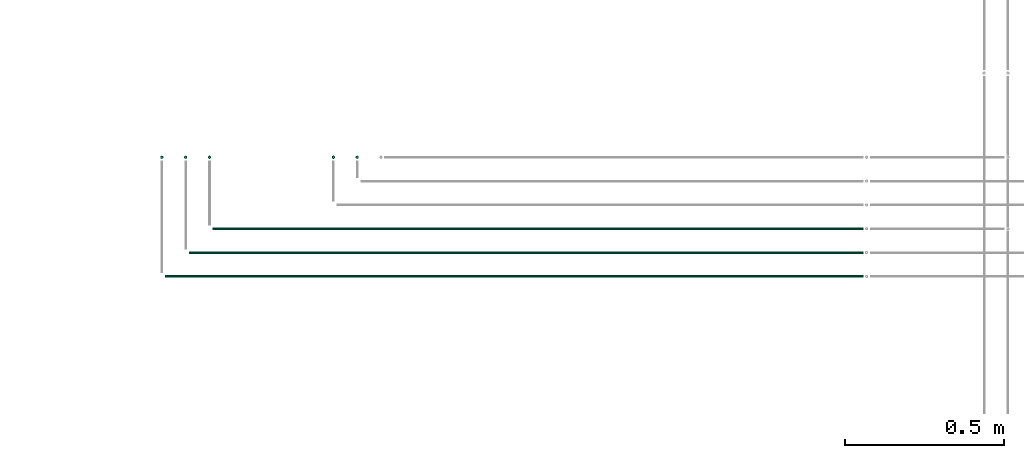
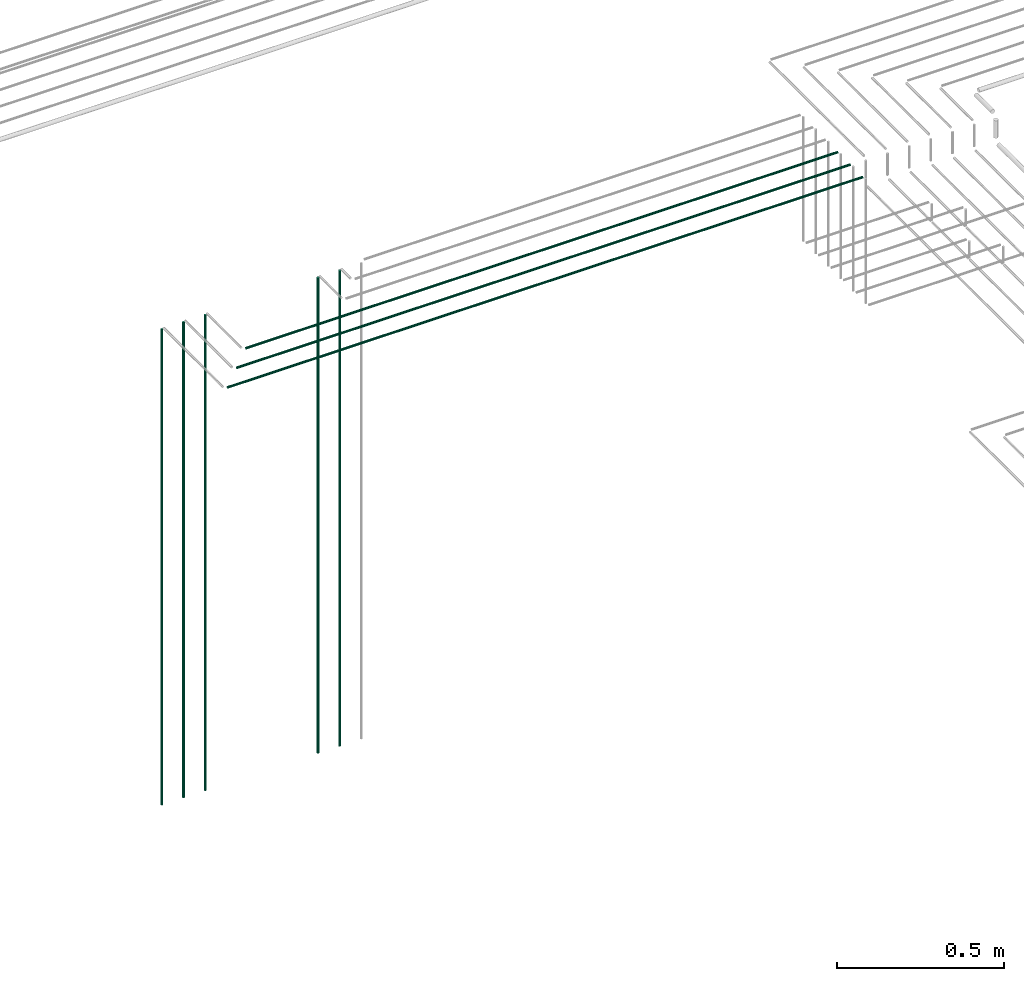
# One storey, part 21 of 89: 8 flow segments.
"""IFC2X3 building model written with IfcOpenShell, lengths in millimetres."""

import ifcopenshell
import ifcopenshell.guid

model = None  # the IFC model being written
_history = None  # IfcOwnerHistory: only IFC2X3 demands one
_inside = {}  # id of a spatial element -> (the spatial element, [elements in it])
_under = {}  # id of a project, library or spatial element -> (it, [spatial elements below it])
_declared = {}  # id of a project -> (the project, [libraries it declares])
_typed = {}  # id of a type object -> (the type object, [elements of that type])
_made_of = {}  # id of a material, layer set ... -> (it, [elements and type objects made of it])


def new_model(schema):
    """Start an empty IFC model of exactly this schema.

    Asked for "IFC4X3", IfcOpenShell would pick the latest addendum, in which some entities
    have other attributes; the version numbers below select the first issue.
    IFC2X3 requires an IfcOwnerHistory on every rooted entity: one is made here for all.
    """
    global model, _history
    if schema == "IFC4X3":
        model = ifcopenshell.file(schema_version=(4, 3, 0, 0))
    else:
        model = ifcopenshell.file(schema=schema)
    _inside.clear()
    _under.clear()
    _declared.clear()
    _typed.clear()
    _made_of.clear()
    _history = None
    if model.schema == "IFC2X3":
        org = make("IfcOrganization", Name="unknown")
        user = make(
            "IfcPersonAndOrganization",
            ThePerson=make("IfcPerson", FamilyName="unknown"),
            TheOrganization=org,
        )
        app = make(
            "IfcApplication",
            ApplicationDeveloper=org,
            Version="unknown",
            ApplicationFullName="unknown",
            ApplicationIdentifier="unknown",
        )
        _history = make(
            "IfcOwnerHistory",
            OwningUser=user,
            OwningApplication=app,
            ChangeAction="ADDED",
            CreationDate=0,
        )
    return model


def make(cls, **values):
    """One entity of the class cls with the attributes given. An attribute that is None is left unset."""
    return model.create_entity(
        cls, **{name: value for name, value in values.items() if value is not None}
    )


def entity(cls, *values):
    """Any entity or typed value of the class cls, its attributes in the order of the schema. None: left unset."""
    e = model.create_entity(cls)
    for i, value in enumerate(values):
        if value is not None:
            e[i] = value
    return e


def rooted(cls, **values):
    """An entity with a GlobalId (a new one), such as an element, a storey or a relation."""
    return make(cls, GlobalId=ifcopenshell.guid.new(), OwnerHistory=_history, **values)


def si_unit(unit_type, name, prefix=None):
    """IfcSIUnit, for example si_unit("LENGTHUNIT", "METRE", prefix="MILLI")."""
    return make("IfcSIUnit", UnitType=unit_type, Prefix=prefix, Name=name)


def converted_unit(unit_type, name, factor, base, dimensions=None, offset=None):
    """IfcConversionBasedUnit, such as the inch: factor (a typed value) times the base unit."""
    return make(
        "IfcConversionBasedUnit"
        if offset is None
        else "IfcConversionBasedUnitWithOffset",
        ConversionOffset=offset,
        Dimensions=None
        if dimensions is None
        else entity("IfcDimensionalExponents", *dimensions),
        UnitType=unit_type,
        Name=name,
        ConversionFactor=make(
            "IfcMeasureWithUnit", ValueComponent=factor, UnitComponent=base
        ),
    )


def derived_unit(unit_type, elements):
    """IfcDerivedUnit: a product of units, each with its exponent."""
    return make(
        "IfcDerivedUnit",
        Elements=[
            make("IfcDerivedUnitElement", Unit=unit, Exponent=power)
            for unit, power in elements
        ],
        UnitType=unit_type,
    )


def assignment(units):
    """IfcUnitAssignment: the units of a project."""
    return None if units is None else make("IfcUnitAssignment", Units=units)


def point(xyz):
    """IfcCartesianPoint."""
    return None if xyz is None else make("IfcCartesianPoint", Coordinates=xyz)


def direction(xyz):
    """IfcDirection."""
    return None if xyz is None else make("IfcDirection", DirectionRatios=xyz)


def frame(location, z_axis=None, x_axis=None):
    """IfcAxis2Placement3D, a coordinate frame: its origin and axes. An axis left out is left unset."""
    return make(
        "IfcAxis2Placement3D",
        Location=point(location),
        Axis=direction(z_axis),
        RefDirection=direction(x_axis),
    )


def frame_2d(location, x_axis=None):
    """IfcAxis2Placement2D, a coordinate frame in the plane: its origin and x axis."""
    return make(
        "IfcAxis2Placement2D", Location=point(location), RefDirection=direction(x_axis)
    )


def origin():
    """The frame at (0, 0, 0) with its axes left unset."""
    return frame((0.0, 0.0, 0.0))


def origin_2d_with_axis():
    """The frame at (0, 0) in the plane with the x axis (1, 0) written out."""
    return frame_2d((0.0, 0.0), x_axis=(1.0, 0.0))


def place(relative_to, where):
    """IfcLocalPlacement: puts the frame where relative to a parent placement (None: the world)."""
    return make(
        "IfcLocalPlacement", PlacementRelTo=relative_to, RelativePlacement=where
    )


def context(
    kind, dimensions, precision=None, world=None, true_north=None, identifier=None
):
    """IfcGeometricRepresentationContext, for example the 3D "Model" context."""
    return make(
        "IfcGeometricRepresentationContext",
        ContextIdentifier=identifier,
        ContextType=kind,
        CoordinateSpaceDimension=dimensions,
        Precision=precision,
        WorldCoordinateSystem=world,
        TrueNorth=true_north,
    )


def subcontext(parent, identifier, kind, view, scale=None):
    """IfcGeometricRepresentationSubContext, for example "Body" below "Model"."""
    return make(
        "IfcGeometricRepresentationSubContext",
        ContextIdentifier=identifier,
        ContextType=kind,
        ParentContext=parent,
        TargetScale=scale,
        TargetView=view,
    )


def project(units=None, contexts=None):
    """IfcProject with its units and contexts."""
    return rooted(
        "IfcProject",
        Name="project",
        RepresentationContexts=contexts,
        UnitsInContext=assignment(units),
    )


def spatial(cls, under=None, at=None, **own):
    """A site, building, storey or space (cls), placed at a placement, below another one or the project."""
    s = rooted(cls, ObjectPlacement=at, **own)
    if under is not None:
        _under.setdefault(under.id(), (under, []))[1].append(s)
    return s


def profile(cls, at=None, kind="AREA", **sizes):
    """A parametric profile (cls). Its sizes go by their IFC names, for example OverallWidth=200.0."""
    return make(cls, ProfileType=kind, Position=at, **sizes)


def circle(**sizes):
    """IfcCircleProfileDef."""
    return profile("IfcCircleProfileDef", **sizes)


def extrude(swept, where, along, depth):
    """IfcExtrudedAreaSolid: the profile swept, set in the frame where, extruded along a direction by depth."""
    return make(
        "IfcExtrudedAreaSolid",
        SweptArea=swept,
        Position=where,
        ExtrudedDirection=direction(along),
        Depth=depth,
    )


def shape(context_of_items, identifier, shape_type, items):
    """IfcShapeRepresentation: the items that make up one representation, for example the "Body"."""
    return make(
        "IfcShapeRepresentation",
        ContextOfItems=context_of_items,
        RepresentationIdentifier=identifier,
        RepresentationType=shape_type,
        Items=items,
    )


def made_of(thing, what):
    """Note that an element or type object is made of a material, layer set ...; save() writes the relation."""
    if what is not None:
        _made_of.setdefault(what.id(), (what, []))[1].append(thing)
    return thing


def type_object(cls, material=None, **own):
    """A type object (cls), such as IfcWallType, which elements share."""
    return made_of(rooted(cls, **own), material)


def element(
    cls,
    number,
    at=None,
    inside=None,
    cuts=None,
    type_object=None,
    material=None,
    context=None,
    identifier="Body",
    shape_type=None,
    held_by="IfcProductDefinitionShape",
    body=None,
    shapes=None,
    **own,
):
    """One element of the class cls, such as IfcWall. Its Tag is "e" and its number.

    at: its placement. inside: the storey or other place that contains it. cuts: it is an
    opening in that element (IfcRelVoidsElement). A single representation is given by context,
    identifier, shape_type and body (its items); several are given by shapes. held_by: the class
    of the entity that holds the representations. save() writes the other relations.
    """
    e = rooted(cls, Tag="e%d" % number, ObjectPlacement=at, **own)
    if body is not None:
        shapes = [shape(context, identifier, shape_type, body)]
    if shapes is not None:
        e.Representation = make(held_by, Representations=shapes)
    if inside is not None:
        _inside.setdefault(inside.id(), (inside, []))[1].append(e)
    if cuts is not None:
        rooted(
            "IfcRelVoidsElement", RelatingBuildingElement=cuts, RelatedOpeningElement=e
        )
    if type_object is not None:
        _typed.setdefault(type_object.id(), (type_object, []))[1].append(e)
    return made_of(e, material)


def aggregate(whole, parts):
    """IfcRelAggregates: a whole, such as a stair, and the parts it consists of."""
    return rooted("IfcRelAggregates", RelatingObject=whole, RelatedObjects=parts)


def save(model, path):
    """Write the relations noted so far, then the file.

    IfcRelAggregates (storeys below a building ...), IfcRelContainedInSpatialStructure (elements
    in a storey), IfcRelDefinesByType, IfcRelAssociatesMaterial and IfcRelDeclares: one each for
    every whole, place, type object, material and project.
    """
    for whole, parts in _under.values():
        aggregate(whole, parts)
    for where, things in _inside.values():
        rooted(
            "IfcRelContainedInSpatialStructure",
            RelatedElements=things,
            RelatingStructure=where,
        )
    for kind, things in _typed.values():
        rooted("IfcRelDefinesByType", RelatedObjects=things, RelatingType=kind)
    for what, things in _made_of.values():
        rooted("IfcRelAssociatesMaterial", RelatedObjects=things, RelatingMaterial=what)
    for by, libraries in _declared.values():
        rooted("IfcRelDeclares", RelatingContext=by, RelatedDefinitions=libraries)
    model.write(path)


model = new_model("IFC2X3")

# Units and contexts
model_context = context("Model", 3, precision=0.01, world=origin(), true_north=direction((6.12303176911189e-17, 1.0)))
body_context = subcontext(model_context, "Body", "Model", "MODEL_VIEW")
ifc_project = project(units=[si_unit("LENGTHUNIT", "METRE", prefix="MILLI"), si_unit("AREAUNIT", "SQUARE_METRE"), si_unit("VOLUMEUNIT", "CUBIC_METRE"), converted_unit("PLANEANGLEUNIT", "DEGREE", entity("IfcRatioMeasure", 0.0174532925199433), si_unit("PLANEANGLEUNIT", "RADIAN"), dimensions=[0, 0, 0, 0, 0, 0, 0]), si_unit("MASSUNIT", "GRAM", prefix="KILO"), derived_unit("MASSDENSITYUNIT", [(si_unit("MASSUNIT", "GRAM", prefix="KILO"), 1), (si_unit("LENGTHUNIT", "METRE"), -3)]), derived_unit("MOMENTOFINERTIAUNIT", [(si_unit("LENGTHUNIT", "METRE"), 4)]), si_unit("TIMEUNIT", "SECOND"), si_unit("FREQUENCYUNIT", "HERTZ"), si_unit("THERMODYNAMICTEMPERATUREUNIT", "DEGREE_CELSIUS"), derived_unit("THERMALTRANSMITTANCEUNIT", [(si_unit("MASSUNIT", "GRAM", prefix="KILO"), 1), (si_unit("THERMODYNAMICTEMPERATUREUNIT", "KELVIN"), -1), (si_unit("TIMEUNIT", "SECOND"), -3)]), derived_unit("VOLUMETRICFLOWRATEUNIT", [(si_unit("LENGTHUNIT", "METRE"), 3), (si_unit("TIMEUNIT", "SECOND"), -1)]), derived_unit("MASSFLOWRATEUNIT", [(si_unit("MASSUNIT", "GRAM", prefix="KILO"), 1), (si_unit("TIMEUNIT", "SECOND"), -1)]), derived_unit("ROTATIONALFREQUENCYUNIT", [(si_unit("TIMEUNIT", "SECOND"), -1)]), si_unit("ELECTRICCURRENTUNIT", "AMPERE"), si_unit("ELECTRICVOLTAGEUNIT", "VOLT"), si_unit("POWERUNIT", "WATT"), si_unit("FORCEUNIT", "NEWTON", prefix="KILO"), si_unit("ILLUMINANCEUNIT", "LUX"), si_unit("LUMINOUSFLUXUNIT", "LUMEN"), si_unit("LUMINOUSINTENSITYUNIT", "CANDELA"), derived_unit("USERDEFINED", [(si_unit("MASSUNIT", "GRAM", prefix="KILO"), -1), (si_unit("LENGTHUNIT", "METRE"), -2), (si_unit("TIMEUNIT", "SECOND"), 3), (si_unit("LUMINOUSFLUXUNIT", "LUMEN"), 1)]), derived_unit("LINEARVELOCITYUNIT", [(si_unit("LENGTHUNIT", "METRE"), 1), (si_unit("TIMEUNIT", "SECOND"), -1)]), si_unit("PRESSUREUNIT", "PASCAL"), derived_unit("USERDEFINED", [(si_unit("LENGTHUNIT", "METRE"), -2), (si_unit("MASSUNIT", "GRAM", prefix="KILO"), 1), (si_unit("TIMEUNIT", "SECOND"), -2)]), derived_unit("LINEARFORCEUNIT", [(si_unit("MASSUNIT", "GRAM", prefix="KILO"), 1), (si_unit("LENGTHUNIT", "METRE"), 1), (si_unit("TIMEUNIT", "SECOND"), -2), (si_unit("LENGTHUNIT", "METRE"), -1)]), derived_unit("PLANARFORCEUNIT", [(si_unit("MASSUNIT", "GRAM", prefix="KILO"), 1), (si_unit("LENGTHUNIT", "METRE"), 1), (si_unit("TIMEUNIT", "SECOND"), -2), (si_unit("LENGTHUNIT", "METRE"), -2)])], contexts=[model_context])

# Site, building, storey
site_placement = place(None, frame((0.0, -0.00077364408347762, 0.0)))
site = spatial("IfcSite", under=ifc_project, at=site_placement, CompositionType="ELEMENT")
building_placement = place(site_placement, origin())
building = spatial("IfcBuilding", under=site, at=building_placement, CompositionType="ELEMENT")
storey_placement = place(building_placement, frame((0.0, 0.0, 24000.0)))
storey = spatial("IfcBuildingStorey", under=building, at=storey_placement, CompositionType="ELEMENT", Elevation=24000.0)

# Flow segments
pipe_segment_type = type_object("IfcPipeSegmentType", PredefinedType="NOTDEFINED")
for number, where in (
    (1, (65615.5981151137, 8369.39395908991, 1400.0)),
    (2, (65540.5985735725, 8369.39395908991, 1400.0)),
):
    element("IfcFlowSegment", number, at=place(storey_placement, frame(where)), inside=storey, type_object=pipe_segment_type, context=body_context, shape_type="SweptSolid", body=[
        extrude(circle(Radius=4.0, at=origin_2d_with_axis()), frame((5.59527223591499, 5.59527223591607, 0.0)), (0.0, 0.0, 1.0), 1740.0),
    ])
flow_segment_1_placement = place(storey_placement, frame((65075.5981151137, 8369.39395908991, 1400.0)))
element("IfcFlowSegment", 3, at=flow_segment_1_placement, inside=storey, type_object=pipe_segment_type, context=body_context, shape_type="SweptSolid", body=[
    extrude(circle(Radius=4.0, at=frame_2d((0.0, 1.08286712929839e-12), x_axis=(1.0, 0.0))), frame((5.59527223591499, 5.59527223591499, 0.0)), (0.0, 0.0, 1.0), 1740.0),
])
flow_segment_2_placement = place(storey_placement, frame((65000.5985735725, 8369.39395908991, 1400.0)))
element("IfcFlowSegment", 4, at=flow_segment_2_placement, inside=storey, type_object=pipe_segment_type, context=body_context, shape_type="SweptSolid", body=[
    extrude(circle(Radius=4.0, at=origin_2d_with_axis()), frame((5.59527223591499, 5.59527223591607, 0.0)), (0.0, 0.0, 1.0), 1740.0),
])
flow_segment_3_placement = place(storey_placement, frame((65091.1933873496, 8069.39395908988, 3144.40472776409)))
element("IfcFlowSegment", 5, at=flow_segment_3_placement, inside=storey, type_object=pipe_segment_type, context=body_context, shape_type="SweptSolid", body=[
    extrude(circle(Radius=4.0, at=origin_2d_with_axis()), frame((0.0, 5.59527223591499, 5.59527223591499), z_axis=(1.0, 0.0, 0.0), x_axis=(0.0, -1.0, 0.0)), (0.0, 0.0, 1.0), 2123.91849592804),
])
flow_segment_4_placement = place(storey_placement, frame((65150.5981151137, 8369.39395908991, 1400.0)))
element("IfcFlowSegment", 6, at=flow_segment_4_placement, inside=storey, type_object=pipe_segment_type, context=body_context, shape_type="SweptSolid", body=[
    extrude(circle(Radius=4.0, at=frame_2d((0.0, 1.08286712929839e-12), x_axis=(1.0, 0.0))), frame((5.59527223591499, 5.59527223591499, 0.0)), (0.0, 0.0, 1.0), 1740.0),
])
flow_segment_5_placement = place(storey_placement, frame((65166.1933873496, 8144.39395908989, 3144.40472776409)))
element("IfcFlowSegment", 7, at=flow_segment_5_placement, inside=storey, type_object=pipe_segment_type, context=body_context, shape_type="SweptSolid", body=[
    extrude(circle(Radius=4.0, at=origin_2d_with_axis()), frame((0.0, 5.59527223591607, 5.59527223591499), z_axis=(1.0, 0.0, 0.0), x_axis=(0.0, -1.0, 0.0)), (0.0, 0.0, 1.0), 2048.91849592802),
])
flow_segment_6_placement = place(storey_placement, frame((65016.1938458084, 7994.39395908987, 3144.40472776409)))
element("IfcFlowSegment", 8, at=flow_segment_6_placement, inside=storey, type_object=pipe_segment_type, context=body_context, shape_type="SweptSolid", body=[
    extrude(circle(Radius=4.0, at=origin_2d_with_axis()), frame((0.0, 5.59527223591499, 5.59527223591499), z_axis=(1.0, 0.0, 0.0), x_axis=(0.0, -1.0, 0.0)), (0.0, 0.0, 1.0), 2198.91803746927),
])

save(model, "model.ifc")
